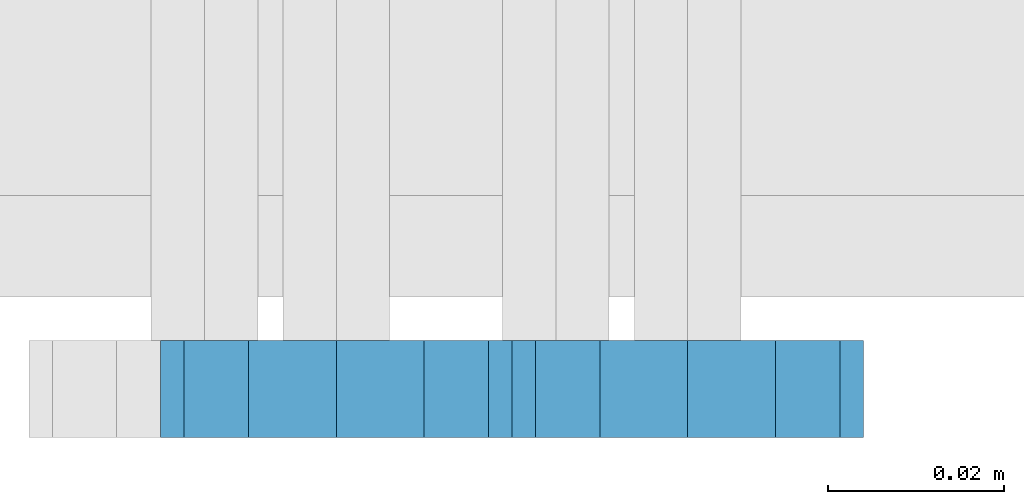
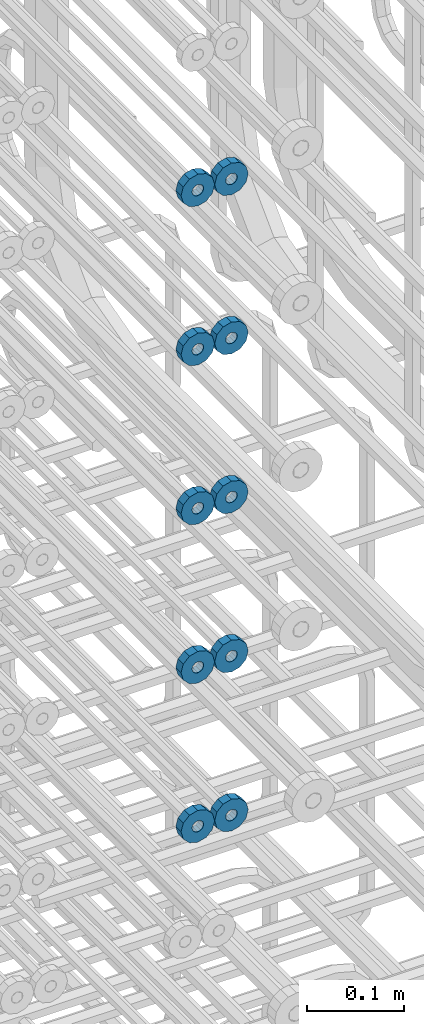
# One storey, part 167 of 177: 10 beams.
"""IFC2X3 building model written with IfcOpenShell, lengths in millimetres."""

import ifcopenshell
import ifcopenshell.guid

model = None  # the IFC model being written
_history = None  # IfcOwnerHistory: only IFC2X3 demands one
_inside = {}  # id of a spatial element -> (the spatial element, [elements in it])
_under = {}  # id of a project, library or spatial element -> (it, [spatial elements below it])
_declared = {}  # id of a project -> (the project, [libraries it declares])
_typed = {}  # id of a type object -> (the type object, [elements of that type])
_made_of = {}  # id of a material, layer set ... -> (it, [elements and type objects made of it])


def new_model(schema):
    """Start an empty IFC model of exactly this schema.

    Asked for "IFC4X3", IfcOpenShell would pick the latest addendum, in which some entities
    have other attributes; the version numbers below select the first issue.
    IFC2X3 requires an IfcOwnerHistory on every rooted entity: one is made here for all.
    """
    global model, _history
    if schema == "IFC4X3":
        model = ifcopenshell.file(schema_version=(4, 3, 0, 0))
    else:
        model = ifcopenshell.file(schema=schema)
    _inside.clear()
    _under.clear()
    _declared.clear()
    _typed.clear()
    _made_of.clear()
    _history = None
    if model.schema == "IFC2X3":
        org = make("IfcOrganization", Name="unknown")
        user = make(
            "IfcPersonAndOrganization",
            ThePerson=make("IfcPerson", FamilyName="unknown"),
            TheOrganization=org,
        )
        app = make(
            "IfcApplication",
            ApplicationDeveloper=org,
            Version="unknown",
            ApplicationFullName="unknown",
            ApplicationIdentifier="unknown",
        )
        _history = make(
            "IfcOwnerHistory",
            OwningUser=user,
            OwningApplication=app,
            ChangeAction="ADDED",
            CreationDate=0,
        )
    return model


def make(cls, **values):
    """One entity of the class cls with the attributes given. An attribute that is None is left unset."""
    return model.create_entity(
        cls, **{name: value for name, value in values.items() if value is not None}
    )


def rooted(cls, **values):
    """An entity with a GlobalId (a new one), such as an element, a storey or a relation."""
    return make(cls, GlobalId=ifcopenshell.guid.new(), OwnerHistory=_history, **values)


def si_unit(unit_type, name, prefix=None):
    """IfcSIUnit, for example si_unit("LENGTHUNIT", "METRE", prefix="MILLI")."""
    return make("IfcSIUnit", UnitType=unit_type, Prefix=prefix, Name=name)


def assignment(units):
    """IfcUnitAssignment: the units of a project."""
    return None if units is None else make("IfcUnitAssignment", Units=units)


def point(xyz):
    """IfcCartesianPoint."""
    return None if xyz is None else make("IfcCartesianPoint", Coordinates=xyz)


def direction(xyz):
    """IfcDirection."""
    return None if xyz is None else make("IfcDirection", DirectionRatios=xyz)


def frame(location, z_axis=None, x_axis=None):
    """IfcAxis2Placement3D, a coordinate frame: its origin and axes. An axis left out is left unset."""
    return make(
        "IfcAxis2Placement3D",
        Location=point(location),
        Axis=direction(z_axis),
        RefDirection=direction(x_axis),
    )


def origin_with_axes():
    """The frame at (0, 0, 0) with the z axis (0, 0, 1) and the x axis (1, 0, 0) written out."""
    return frame((0.0, 0.0, 0.0), z_axis=(0.0, 0.0, 1.0), x_axis=(1.0, 0.0, 0.0))


def place(relative_to, where):
    """IfcLocalPlacement: puts the frame where relative to a parent placement (None: the world)."""
    return make(
        "IfcLocalPlacement", PlacementRelTo=relative_to, RelativePlacement=where
    )


def context(
    kind, dimensions, precision=None, world=None, true_north=None, identifier=None
):
    """IfcGeometricRepresentationContext, for example the 3D "Model" context."""
    return make(
        "IfcGeometricRepresentationContext",
        ContextIdentifier=identifier,
        ContextType=kind,
        CoordinateSpaceDimension=dimensions,
        Precision=precision,
        WorldCoordinateSystem=world,
        TrueNorth=true_north,
    )


def subcontext(parent, identifier, kind, view, scale=None):
    """IfcGeometricRepresentationSubContext, for example "Body" below "Model"."""
    return make(
        "IfcGeometricRepresentationSubContext",
        ContextIdentifier=identifier,
        ContextType=kind,
        ParentContext=parent,
        TargetScale=scale,
        TargetView=view,
    )


def project(units=None, contexts=None):
    """IfcProject with its units and contexts."""
    return rooted(
        "IfcProject",
        Name="project",
        RepresentationContexts=contexts,
        UnitsInContext=assignment(units),
    )


def spatial(cls, under=None, at=None, **own):
    """A site, building, storey or space (cls), placed at a placement, below another one or the project."""
    s = rooted(cls, ObjectPlacement=at, **own)
    if under is not None:
        _under.setdefault(under.id(), (under, []))[1].append(s)
    return s


def faces_of(points, faces, orient=None, outer=None):
    """IfcFace entities. A face is a list of loops; a loop is a list of indices into points, from 0.

    orient and outer hold one flag for each loop. By default every Orientation is true, the
    first loop of a face is its IfcFaceOuterBound and the others are IfcFaceBound.
    """
    made = []
    for i, loops in enumerate(faces):
        bounds = []
        for j, loop in enumerate(loops):
            is_outer = j == 0 if outer is None else outer[i][j]
            bounds.append(
                make(
                    "IfcFaceOuterBound" if is_outer else "IfcFaceBound",
                    Bound=make("IfcPolyLoop", Polygon=[points[k] for k in loop]),
                    Orientation=True if orient is None else orient[i][j],
                )
            )
        made.append(make("IfcFace", Bounds=bounds))
    return made


def faceted_brep(points, faces, orient=None, outer=None, voids=None):
    """IfcFacetedBrep: a solid bounded by flat faces; with voids (closed shells), ...WithVoids."""
    shared = [point(p) for p in points]
    hull = make("IfcClosedShell", CfsFaces=faces_of(shared, faces, orient, outer))
    if voids is None:
        return make("IfcFacetedBrep", Outer=hull)
    return make(
        "IfcFacetedBrepWithVoids",
        Outer=hull,
        Voids=[
            make(cls, CfsFaces=faces_of(shared, fs, o, b)) for cls, fs, o, b in voids
        ],
    )


def shape(context_of_items, identifier, shape_type, items):
    """IfcShapeRepresentation: the items that make up one representation, for example the "Body"."""
    return make(
        "IfcShapeRepresentation",
        ContextOfItems=context_of_items,
        RepresentationIdentifier=identifier,
        RepresentationType=shape_type,
        Items=items,
    )


def material(Name=None, Category=None):
    """IfcMaterial."""
    return make("IfcMaterial", Name=Name, Category=Category)


def made_of(thing, what):
    """Note that an element or type object is made of a material, layer set ...; save() writes the relation."""
    if what is not None:
        _made_of.setdefault(what.id(), (what, []))[1].append(thing)
    return thing


def type_object(cls, material=None, **own):
    """A type object (cls), such as IfcWallType, which elements share."""
    return made_of(rooted(cls, **own), material)


def element(
    cls,
    number,
    at=None,
    inside=None,
    cuts=None,
    type_object=None,
    material=None,
    context=None,
    identifier="Body",
    shape_type=None,
    held_by="IfcProductDefinitionShape",
    body=None,
    shapes=None,
    **own,
):
    """One element of the class cls, such as IfcWall. Its Tag is "e" and its number.

    at: its placement. inside: the storey or other place that contains it. cuts: it is an
    opening in that element (IfcRelVoidsElement). A single representation is given by context,
    identifier, shape_type and body (its items); several are given by shapes. held_by: the class
    of the entity that holds the representations. save() writes the other relations.
    """
    e = rooted(cls, Tag="e%d" % number, ObjectPlacement=at, **own)
    if body is not None:
        shapes = [shape(context, identifier, shape_type, body)]
    if shapes is not None:
        e.Representation = make(held_by, Representations=shapes)
    if inside is not None:
        _inside.setdefault(inside.id(), (inside, []))[1].append(e)
    if cuts is not None:
        rooted(
            "IfcRelVoidsElement", RelatingBuildingElement=cuts, RelatedOpeningElement=e
        )
    if type_object is not None:
        _typed.setdefault(type_object.id(), (type_object, []))[1].append(e)
    return made_of(e, material)


def aggregate(whole, parts):
    """IfcRelAggregates: a whole, such as a stair, and the parts it consists of."""
    return rooted("IfcRelAggregates", RelatingObject=whole, RelatedObjects=parts)


def save(model, path):
    """Write the relations noted so far, then the file.

    IfcRelAggregates (storeys below a building ...), IfcRelContainedInSpatialStructure (elements
    in a storey), IfcRelDefinesByType, IfcRelAssociatesMaterial and IfcRelDeclares: one each for
    every whole, place, type object, material and project.
    """
    for whole, parts in _under.values():
        aggregate(whole, parts)
    for where, things in _inside.values():
        rooted(
            "IfcRelContainedInSpatialStructure",
            RelatedElements=things,
            RelatingStructure=where,
        )
    for kind, things in _typed.values():
        rooted("IfcRelDefinesByType", RelatedObjects=things, RelatingType=kind)
    for what, things in _made_of.values():
        rooted("IfcRelAssociatesMaterial", RelatedObjects=things, RelatingMaterial=what)
    for by, libraries in _declared.values():
        rooted("IfcRelDeclares", RelatingContext=by, RelatedDefinitions=libraries)
    model.write(path)


model = new_model("IFC2X3")

# Units and contexts
model_context_1 = context("Model", 3, precision=1e-05, world=origin_with_axes())
model_context_2 = context("Model", 3, precision=1e-05, world=origin_with_axes())
body_context = subcontext(model_context_2, "Body", "Model", "MODEL_VIEW")
ifc_project = project(units=[si_unit("LENGTHUNIT", "METRE", prefix="MILLI"), si_unit("AREAUNIT", "SQUARE_METRE"), si_unit("VOLUMEUNIT", "CUBIC_METRE"), si_unit("MASSUNIT", "GRAM", prefix="KILO"), si_unit("TIMEUNIT", "SECOND"), si_unit("PLANEANGLEUNIT", "RADIAN"), si_unit("SOLIDANGLEUNIT", "STERADIAN"), si_unit("THERMODYNAMICTEMPERATUREUNIT", "DEGREE_CELSIUS"), si_unit("LUMINOUSINTENSITYUNIT", "LUMEN")], contexts=[model_context_1])

# Site, building, storey
site_placement = place(None, origin_with_axes())
site = spatial("IfcSite", under=ifc_project, at=site_placement, CompositionType="ELEMENT")
building_placement = place(site_placement, origin_with_axes())
building = spatial("IfcBuilding", under=site, at=building_placement, Name="Undefined", CompositionType="ELEMENT")
storey_placement = place(building_placement, origin_with_axes())
storey = spatial("IfcBuildingStorey", under=building, at=storey_placement, Name="Undefined", CompositionType="ELEMENT", Elevation=0.0)

# Beams
ifc_material = material(Name="STEEL/Steel_Undefined")
beam_type = type_object("IfcBeamType", PredefinedType="NOTDEFINED")
beam_1_placement = place(storey_placement, frame((2036046.99847313, 6205070.98588032, 21944.9868114254), z_axis=(0.0, 0.0, -1.0), x_axis=(0.0, -1.0, 0.0)))
element("IfcBeam", 1, at=beam_1_placement, inside=storey, type_object=beam_type, material=ifc_material, context=body_context, shape_type="Brep", body=[
    faceted_brep([(-3.63797880709171e-12, -7.0, -2.3283064365387e-10), (-8.62348444298797e-13, -6.06217782649107, 3.5), (10.9999999999964, -6.06217782665044, 3.49999999976717), (10.9999999999964, -7.0, -2.3283064365387e-10), (-3.63797880709171e-12, -3.5, 6.06217782618478), (11.0, -3.5, 6.06217782618478), (-1.72469688859759e-12, 0.0, 7.0), (11.0, 0.0, 6.99999999976717), (-3.63797880709171e-12, 3.5, 6.06217782618478), (11.0, 3.5, 6.06217782618478), (-8.62348444298795e-13, 6.06217782649107, 3.5), (10.9999999999964, 6.06217782665044, 3.49999999976717), (-3.63797880709171e-12, 7.0, -2.3283064365387e-10), (10.9999999999964, 7.0, -2.3283064365387e-10), (8.62348444298797e-13, 6.06217782649107, -3.5), (10.9999999999964, 6.06217782665044, -3.50000000023283), (-3.63797880709171e-12, 3.5, -6.06217782665044), (10.9999999999964, 3.5, -6.06217782665044), (1.72469688859759e-12, -2.72004641033163e-15, -7.0), (10.9999999999964, 0.0, -7.00000000023283), (-3.63797880709171e-12, -3.5, -6.06217782665044), (10.9999999999964, -3.5, -6.06217782665044), (8.62348444298796e-13, -6.06217782649107, -3.5), (10.9999999999964, -6.06217782665044, -3.50000000023283), (0.0, -20.0000000009313, 0.0), (0.0, -17.320508075878, -10.0), (10.9999999999964, -17.320508075878, -10.0000000002328), (10.9999999999964, -20.0, -2.3283064365387e-10), (0.0, -10.0000000009313, -17.3205080756452), (11.0, -10.0, -17.320508075878), (0.0, -1.86264514923096e-09, -19.9999999998836), (10.9999999999964, 0.0, -20.0000000002328), (0.0, 9.99999999906868, -17.3205080755288), (11.0, 10.0, -17.320508075878), (0.0, 17.320508075878, -10.0), (10.9999999999964, 17.320508075878, -10.0000000002328), (0.0, 19.9999999990687, 0.0), (10.9999999999964, 20.0, -2.3283064365387e-10), (0.0, 17.3205080740154, 10.0), (11.0, 17.320508075878, 9.99999999976717), (0.0, 9.99999999906868, 17.3205080757616), (10.9999999999964, 10.0, 17.3205080754124), (0.0, 0.0, 20.0000000001164), (10.9999999999964, 0.0, 19.9999999997672), (0.0, -10.0000000009313, 17.3205080757616), (10.9999999999964, -10.0, 17.3205080754124), (0.0, -17.3205080777407, 10.0000000001164), (11.0, -17.320508075878, 9.99999999976717)], [[[0, 1, 2, 3]], [[1, 4, 5, 2]], [[4, 6, 7, 5]], [[6, 8, 9, 7]], [[8, 10, 11, 9]], [[10, 12, 13, 11]], [[12, 14, 15, 13]], [[14, 16, 17, 15]], [[16, 18, 19, 17]], [[18, 20, 21, 19]], [[20, 22, 23, 21]], [[22, 0, 3, 23]], [[24, 25, 26, 27]], [[25, 28, 29, 26]], [[28, 30, 31, 29]], [[30, 32, 33, 31]], [[32, 34, 35, 33]], [[34, 36, 37, 35]], [[36, 38, 39, 37]], [[38, 40, 41, 39]], [[40, 42, 43, 41]], [[42, 44, 45, 43]], [[44, 46, 47, 45]], [[46, 24, 27, 47]], [[29, 31, 33, 35, 37, 39, 41, 43, 45, 47, 27, 26], [5, 7, 9, 11, 13, 15, 17, 19, 21, 23, 3, 2]], [[46, 44, 42, 40, 38, 36, 34, 32, 30, 28, 25, 24], [22, 20, 18, 16, 14, 12, 10, 8, 6, 4, 1, 0]]]),
])
beam_2_placement = place(storey_placement, frame((2036006.99847313, 6205070.98588032, 21944.9868114254), z_axis=(0.0, 0.0, -1.0), x_axis=(0.0, -1.0, 0.0)))
element("IfcBeam", 2, at=beam_2_placement, inside=storey, type_object=beam_type, material=ifc_material, context=body_context, shape_type="Brep", body=[
    faceted_brep([(-3.63797880709171e-12, -7.0, -2.3283064365387e-10), (-8.62348444298797e-13, -6.06217782649107, 3.5), (10.9999999999964, -6.06217782665044, 3.49999999976717), (10.9999999999964, -7.0, -2.3283064365387e-10), (-3.63797880709171e-12, -3.5, 6.06217782618478), (11.0, -3.5, 6.06217782618478), (-1.72469688859759e-12, 0.0, 7.0), (11.0, 0.0, 6.99999999976717), (-3.63797880709171e-12, 3.5, 6.06217782618478), (11.0, 3.5, 6.06217782618478), (-8.62348444298795e-13, 6.06217782649107, 3.5), (10.9999999999964, 6.06217782665044, 3.49999999976717), (-3.63797880709171e-12, 7.0, -2.3283064365387e-10), (10.9999999999964, 7.0, -2.3283064365387e-10), (8.62348444298797e-13, 6.06217782649107, -3.5), (10.9999999999964, 6.06217782665044, -3.50000000023283), (-3.63797880709171e-12, 3.5, -6.06217782665044), (10.9999999999964, 3.5, -6.06217782665044), (1.72469688859759e-12, -2.72004641033163e-15, -7.0), (10.9999999999964, 0.0, -7.00000000023283), (-3.63797880709171e-12, -3.5, -6.06217782665044), (10.9999999999964, -3.5, -6.06217782665044), (8.62348444298796e-13, -6.06217782649107, -3.5), (10.9999999999964, -6.06217782665044, -3.50000000023283), (0.0, -20.0000000009313, 0.0), (0.0, -17.320508075878, -10.0), (10.9999999999964, -17.320508075878, -10.0000000002328), (10.9999999999964, -20.0, -2.3283064365387e-10), (0.0, -10.0000000009313, -17.3205080756452), (11.0, -10.0, -17.320508075878), (0.0, -1.86264514923096e-09, -19.9999999998836), (10.9999999999964, 0.0, -20.0000000002328), (0.0, 9.99999999906868, -17.3205080755288), (11.0, 10.0, -17.320508075878), (0.0, 17.320508075878, -10.0), (10.9999999999964, 17.320508075878, -10.0000000002328), (0.0, 19.9999999990687, 0.0), (10.9999999999964, 20.0, -2.3283064365387e-10), (0.0, 17.3205080740154, 10.0), (11.0, 17.320508075878, 9.99999999976717), (0.0, 9.99999999906868, 17.3205080757616), (10.9999999999964, 10.0, 17.3205080754124), (0.0, 0.0, 20.0000000001164), (10.9999999999964, 0.0, 19.9999999997672), (0.0, -10.0000000009313, 17.3205080757616), (10.9999999999964, -10.0, 17.3205080754124), (0.0, -17.3205080777407, 10.0000000001164), (11.0, -17.320508075878, 9.99999999976717)], [[[0, 1, 2, 3]], [[1, 4, 5, 2]], [[4, 6, 7, 5]], [[6, 8, 9, 7]], [[8, 10, 11, 9]], [[10, 12, 13, 11]], [[12, 14, 15, 13]], [[14, 16, 17, 15]], [[16, 18, 19, 17]], [[18, 20, 21, 19]], [[20, 22, 23, 21]], [[22, 0, 3, 23]], [[24, 25, 26, 27]], [[25, 28, 29, 26]], [[28, 30, 31, 29]], [[30, 32, 33, 31]], [[32, 34, 35, 33]], [[34, 36, 37, 35]], [[36, 38, 39, 37]], [[38, 40, 41, 39]], [[40, 42, 43, 41]], [[42, 44, 45, 43]], [[44, 46, 47, 45]], [[46, 24, 27, 47]], [[29, 31, 33, 35, 37, 39, 41, 43, 45, 47, 27, 26], [5, 7, 9, 11, 13, 15, 17, 19, 21, 23, 3, 2]], [[46, 44, 42, 40, 38, 36, 34, 32, 30, 28, 25, 24], [22, 20, 18, 16, 14, 12, 10, 8, 6, 4, 1, 0]]]),
])
beam_3_placement = place(storey_placement, frame((2036046.99847313, 6205070.98588032, 21744.9868114254), z_axis=(0.0, 0.0, -1.0), x_axis=(0.0, -1.0, 0.0)))
element("IfcBeam", 3, at=beam_3_placement, inside=storey, type_object=beam_type, material=ifc_material, context=body_context, shape_type="Brep", body=[
    faceted_brep([(-3.63797880709171e-12, -7.0, -2.3283064365387e-10), (-8.62348444298797e-13, -6.06217782649107, 3.5), (10.9999999999964, -6.06217782665044, 3.49999999976717), (10.9999999999964, -7.0, -2.3283064365387e-10), (-3.63797880709171e-12, -3.5, 6.06217782618478), (11.0, -3.5, 6.06217782618478), (-1.72469688859759e-12, 0.0, 7.0), (11.0, 0.0, 6.99999999976717), (-3.63797880709171e-12, 3.5, 6.06217782618478), (11.0, 3.5, 6.06217782618478), (-8.62348444298795e-13, 6.06217782649107, 3.5), (10.9999999999964, 6.06217782665044, 3.49999999976717), (-3.63797880709171e-12, 7.0, -2.3283064365387e-10), (10.9999999999964, 7.0, -2.3283064365387e-10), (8.62348444298797e-13, 6.06217782649107, -3.5), (10.9999999999964, 6.06217782665044, -3.50000000023283), (-3.63797880709171e-12, 3.5, -6.06217782665044), (10.9999999999964, 3.5, -6.06217782665044), (1.72469688859759e-12, -2.72004641033163e-15, -7.0), (10.9999999999964, 0.0, -7.00000000023283), (-3.63797880709171e-12, -3.5, -6.06217782665044), (10.9999999999964, -3.5, -6.06217782665044), (8.62348444298796e-13, -6.06217782649107, -3.5), (10.9999999999964, -6.06217782665044, -3.50000000023283), (0.0, -20.0000000009313, 0.0), (0.0, -17.320508075878, -10.0), (10.9999999999964, -17.320508075878, -10.0000000002328), (10.9999999999964, -20.0, -2.3283064365387e-10), (0.0, -10.0000000009313, -17.3205080756452), (11.0, -10.0, -17.320508075878), (0.0, -1.86264514923096e-09, -19.9999999998836), (10.9999999999964, 0.0, -20.0000000002328), (0.0, 9.99999999906868, -17.3205080755288), (11.0, 10.0, -17.320508075878), (0.0, 17.320508075878, -10.0), (10.9999999999964, 17.320508075878, -10.0000000002328), (0.0, 19.9999999990687, 0.0), (10.9999999999964, 20.0, -2.3283064365387e-10), (0.0, 17.3205080740154, 10.0), (11.0, 17.320508075878, 9.99999999976717), (0.0, 9.99999999906868, 17.3205080757616), (10.9999999999964, 10.0, 17.3205080754124), (0.0, 0.0, 20.0000000001164), (10.9999999999964, 0.0, 19.9999999997672), (0.0, -10.0000000009313, 17.3205080757616), (10.9999999999964, -10.0, 17.3205080754124), (0.0, -17.3205080777407, 10.0000000001164), (11.0, -17.320508075878, 9.99999999976717)], [[[0, 1, 2, 3]], [[1, 4, 5, 2]], [[4, 6, 7, 5]], [[6, 8, 9, 7]], [[8, 10, 11, 9]], [[10, 12, 13, 11]], [[12, 14, 15, 13]], [[14, 16, 17, 15]], [[16, 18, 19, 17]], [[18, 20, 21, 19]], [[20, 22, 23, 21]], [[22, 0, 3, 23]], [[24, 25, 26, 27]], [[25, 28, 29, 26]], [[28, 30, 31, 29]], [[30, 32, 33, 31]], [[32, 34, 35, 33]], [[34, 36, 37, 35]], [[36, 38, 39, 37]], [[38, 40, 41, 39]], [[40, 42, 43, 41]], [[42, 44, 45, 43]], [[44, 46, 47, 45]], [[46, 24, 27, 47]], [[29, 31, 33, 35, 37, 39, 41, 43, 45, 47, 27, 26], [5, 7, 9, 11, 13, 15, 17, 19, 21, 23, 3, 2]], [[46, 44, 42, 40, 38, 36, 34, 32, 30, 28, 25, 24], [22, 20, 18, 16, 14, 12, 10, 8, 6, 4, 1, 0]]]),
])
beam_4_placement = place(storey_placement, frame((2036006.99847313, 6205070.98588032, 21744.9868114254), z_axis=(0.0, 0.0, -1.0), x_axis=(0.0, -1.0, 0.0)))
element("IfcBeam", 4, at=beam_4_placement, inside=storey, type_object=beam_type, material=ifc_material, context=body_context, shape_type="Brep", body=[
    faceted_brep([(-3.63797880709171e-12, -7.0, -2.3283064365387e-10), (-8.62348444298797e-13, -6.06217782649107, 3.5), (10.9999999999964, -6.06217782665044, 3.49999999976717), (10.9999999999964, -7.0, -2.3283064365387e-10), (-3.63797880709171e-12, -3.5, 6.06217782618478), (11.0, -3.5, 6.06217782618478), (-1.72469688859759e-12, 0.0, 7.0), (11.0, 0.0, 6.99999999976717), (-3.63797880709171e-12, 3.5, 6.06217782618478), (11.0, 3.5, 6.06217782618478), (-8.62348444298795e-13, 6.06217782649107, 3.5), (10.9999999999964, 6.06217782665044, 3.49999999976717), (-3.63797880709171e-12, 7.0, -2.3283064365387e-10), (10.9999999999964, 7.0, -2.3283064365387e-10), (8.62348444298797e-13, 6.06217782649107, -3.5), (10.9999999999964, 6.06217782665044, -3.50000000023283), (-3.63797880709171e-12, 3.5, -6.06217782665044), (10.9999999999964, 3.5, -6.06217782665044), (1.72469688859759e-12, -2.72004641033163e-15, -7.0), (10.9999999999964, 0.0, -7.00000000023283), (-3.63797880709171e-12, -3.5, -6.06217782665044), (10.9999999999964, -3.5, -6.06217782665044), (8.62348444298796e-13, -6.06217782649107, -3.5), (10.9999999999964, -6.06217782665044, -3.50000000023283), (0.0, -20.0000000009313, 0.0), (0.0, -17.320508075878, -10.0), (10.9999999999964, -17.320508075878, -10.0000000002328), (10.9999999999964, -20.0, -2.3283064365387e-10), (0.0, -10.0000000009313, -17.3205080756452), (11.0, -10.0, -17.320508075878), (0.0, -1.86264514923096e-09, -19.9999999998836), (10.9999999999964, 0.0, -20.0000000002328), (0.0, 9.99999999906868, -17.3205080755288), (11.0, 10.0, -17.320508075878), (0.0, 17.320508075878, -10.0), (10.9999999999964, 17.320508075878, -10.0000000002328), (0.0, 19.9999999990687, 0.0), (10.9999999999964, 20.0, -2.3283064365387e-10), (0.0, 17.3205080740154, 10.0), (11.0, 17.320508075878, 9.99999999976717), (0.0, 9.99999999906868, 17.3205080757616), (10.9999999999964, 10.0, 17.3205080754124), (0.0, 0.0, 20.0000000001164), (10.9999999999964, 0.0, 19.9999999997672), (0.0, -10.0000000009313, 17.3205080757616), (10.9999999999964, -10.0, 17.3205080754124), (0.0, -17.3205080777407, 10.0000000001164), (11.0, -17.320508075878, 9.99999999976717)], [[[0, 1, 2, 3]], [[1, 4, 5, 2]], [[4, 6, 7, 5]], [[6, 8, 9, 7]], [[8, 10, 11, 9]], [[10, 12, 13, 11]], [[12, 14, 15, 13]], [[14, 16, 17, 15]], [[16, 18, 19, 17]], [[18, 20, 21, 19]], [[20, 22, 23, 21]], [[22, 0, 3, 23]], [[24, 25, 26, 27]], [[25, 28, 29, 26]], [[28, 30, 31, 29]], [[30, 32, 33, 31]], [[32, 34, 35, 33]], [[34, 36, 37, 35]], [[36, 38, 39, 37]], [[38, 40, 41, 39]], [[40, 42, 43, 41]], [[42, 44, 45, 43]], [[44, 46, 47, 45]], [[46, 24, 27, 47]], [[29, 31, 33, 35, 37, 39, 41, 43, 45, 47, 27, 26], [5, 7, 9, 11, 13, 15, 17, 19, 21, 23, 3, 2]], [[46, 44, 42, 40, 38, 36, 34, 32, 30, 28, 25, 24], [22, 20, 18, 16, 14, 12, 10, 8, 6, 4, 1, 0]]]),
])
beam_5_placement = place(storey_placement, frame((2036046.99847313, 6205070.98588032, 21544.9868114254), z_axis=(0.0, 0.0, -1.0), x_axis=(0.0, -1.0, 0.0)))
element("IfcBeam", 5, at=beam_5_placement, inside=storey, type_object=beam_type, material=ifc_material, context=body_context, shape_type="Brep", body=[
    faceted_brep([(-3.63797880709171e-12, -7.0, -2.3283064365387e-10), (-8.62348444298797e-13, -6.06217782649107, 3.5), (10.9999999999964, -6.06217782665044, 3.49999999976717), (10.9999999999964, -7.0, -2.3283064365387e-10), (-3.63797880709171e-12, -3.5, 6.06217782618478), (11.0, -3.5, 6.06217782618478), (-1.72469688859759e-12, 0.0, 7.0), (11.0, 0.0, 6.99999999976717), (-3.63797880709171e-12, 3.5, 6.06217782618478), (11.0, 3.5, 6.06217782618478), (-8.62348444298795e-13, 6.06217782649107, 3.5), (10.9999999999964, 6.06217782665044, 3.49999999976717), (-3.63797880709171e-12, 7.0, -2.3283064365387e-10), (10.9999999999964, 7.0, -2.3283064365387e-10), (8.62348444298797e-13, 6.06217782649107, -3.5), (10.9999999999964, 6.06217782665044, -3.50000000023283), (-3.63797880709171e-12, 3.5, -6.06217782665044), (10.9999999999964, 3.5, -6.06217782665044), (1.72469688859759e-12, -2.72004641033163e-15, -7.0), (10.9999999999964, 0.0, -7.00000000023283), (-3.63797880709171e-12, -3.5, -6.06217782665044), (10.9999999999964, -3.5, -6.06217782665044), (8.62348444298796e-13, -6.06217782649107, -3.5), (10.9999999999964, -6.06217782665044, -3.50000000023283), (0.0, -20.0000000009313, 0.0), (0.0, -17.320508075878, -10.0), (10.9999999999964, -17.320508075878, -10.0000000002328), (10.9999999999964, -20.0, -2.3283064365387e-10), (0.0, -10.0000000009313, -17.3205080756452), (11.0, -10.0, -17.320508075878), (0.0, -1.86264514923096e-09, -19.9999999998836), (10.9999999999964, 0.0, -20.0000000002328), (0.0, 9.99999999906868, -17.3205080755288), (11.0, 10.0, -17.320508075878), (0.0, 17.320508075878, -10.0), (10.9999999999964, 17.320508075878, -10.0000000002328), (0.0, 19.9999999990687, 0.0), (10.9999999999964, 20.0, -2.3283064365387e-10), (0.0, 17.3205080740154, 10.0), (11.0, 17.320508075878, 9.99999999976717), (0.0, 9.99999999906868, 17.3205080757616), (10.9999999999964, 10.0, 17.3205080754124), (0.0, 0.0, 20.0000000001164), (10.9999999999964, 0.0, 19.9999999997672), (0.0, -10.0000000009313, 17.3205080757616), (10.9999999999964, -10.0, 17.3205080754124), (0.0, -17.3205080777407, 10.0000000001164), (11.0, -17.320508075878, 9.99999999976717)], [[[0, 1, 2, 3]], [[1, 4, 5, 2]], [[4, 6, 7, 5]], [[6, 8, 9, 7]], [[8, 10, 11, 9]], [[10, 12, 13, 11]], [[12, 14, 15, 13]], [[14, 16, 17, 15]], [[16, 18, 19, 17]], [[18, 20, 21, 19]], [[20, 22, 23, 21]], [[22, 0, 3, 23]], [[24, 25, 26, 27]], [[25, 28, 29, 26]], [[28, 30, 31, 29]], [[30, 32, 33, 31]], [[32, 34, 35, 33]], [[34, 36, 37, 35]], [[36, 38, 39, 37]], [[38, 40, 41, 39]], [[40, 42, 43, 41]], [[42, 44, 45, 43]], [[44, 46, 47, 45]], [[46, 24, 27, 47]], [[29, 31, 33, 35, 37, 39, 41, 43, 45, 47, 27, 26], [5, 7, 9, 11, 13, 15, 17, 19, 21, 23, 3, 2]], [[46, 44, 42, 40, 38, 36, 34, 32, 30, 28, 25, 24], [22, 20, 18, 16, 14, 12, 10, 8, 6, 4, 1, 0]]]),
])
beam_6_placement = place(storey_placement, frame((2036006.99847313, 6205070.98588032, 21544.9868114254), z_axis=(0.0, 0.0, -1.0), x_axis=(0.0, -1.0, 0.0)))
element("IfcBeam", 6, at=beam_6_placement, inside=storey, type_object=beam_type, material=ifc_material, context=body_context, shape_type="Brep", body=[
    faceted_brep([(-3.63797880709171e-12, -7.0, -2.3283064365387e-10), (-8.62348444298797e-13, -6.06217782649107, 3.5), (10.9999999999964, -6.06217782665044, 3.49999999976717), (10.9999999999964, -7.0, -2.3283064365387e-10), (-3.63797880709171e-12, -3.5, 6.06217782618478), (11.0, -3.5, 6.06217782618478), (-1.72469688859759e-12, 0.0, 7.0), (11.0, 0.0, 6.99999999976717), (-3.63797880709171e-12, 3.5, 6.06217782618478), (11.0, 3.5, 6.06217782618478), (-8.62348444298795e-13, 6.06217782649107, 3.5), (10.9999999999964, 6.06217782665044, 3.49999999976717), (-3.63797880709171e-12, 7.0, -2.3283064365387e-10), (10.9999999999964, 7.0, -2.3283064365387e-10), (8.62348444298797e-13, 6.06217782649107, -3.5), (10.9999999999964, 6.06217782665044, -3.50000000023283), (-3.63797880709171e-12, 3.5, -6.06217782665044), (10.9999999999964, 3.5, -6.06217782665044), (1.72469688859759e-12, -2.72004641033163e-15, -7.0), (10.9999999999964, 0.0, -7.00000000023283), (-3.63797880709171e-12, -3.5, -6.06217782665044), (10.9999999999964, -3.5, -6.06217782665044), (8.62348444298796e-13, -6.06217782649107, -3.5), (10.9999999999964, -6.06217782665044, -3.50000000023283), (0.0, -20.0000000009313, 0.0), (0.0, -17.320508075878, -10.0), (10.9999999999964, -17.320508075878, -10.0000000002328), (10.9999999999964, -20.0, -2.3283064365387e-10), (0.0, -10.0000000009313, -17.3205080756452), (11.0, -10.0, -17.320508075878), (0.0, -1.86264514923096e-09, -19.9999999998836), (10.9999999999964, 0.0, -20.0000000002328), (0.0, 9.99999999906868, -17.3205080755288), (11.0, 10.0, -17.320508075878), (0.0, 17.320508075878, -10.0), (10.9999999999964, 17.320508075878, -10.0000000002328), (0.0, 19.9999999990687, 0.0), (10.9999999999964, 20.0, -2.3283064365387e-10), (0.0, 17.3205080740154, 10.0), (11.0, 17.320508075878, 9.99999999976717), (0.0, 9.99999999906868, 17.3205080757616), (10.9999999999964, 10.0, 17.3205080754124), (0.0, 0.0, 20.0000000001164), (10.9999999999964, 0.0, 19.9999999997672), (0.0, -10.0000000009313, 17.3205080757616), (10.9999999999964, -10.0, 17.3205080754124), (0.0, -17.3205080777407, 10.0000000001164), (11.0, -17.320508075878, 9.99999999976717)], [[[0, 1, 2, 3]], [[1, 4, 5, 2]], [[4, 6, 7, 5]], [[6, 8, 9, 7]], [[8, 10, 11, 9]], [[10, 12, 13, 11]], [[12, 14, 15, 13]], [[14, 16, 17, 15]], [[16, 18, 19, 17]], [[18, 20, 21, 19]], [[20, 22, 23, 21]], [[22, 0, 3, 23]], [[24, 25, 26, 27]], [[25, 28, 29, 26]], [[28, 30, 31, 29]], [[30, 32, 33, 31]], [[32, 34, 35, 33]], [[34, 36, 37, 35]], [[36, 38, 39, 37]], [[38, 40, 41, 39]], [[40, 42, 43, 41]], [[42, 44, 45, 43]], [[44, 46, 47, 45]], [[46, 24, 27, 47]], [[29, 31, 33, 35, 37, 39, 41, 43, 45, 47, 27, 26], [5, 7, 9, 11, 13, 15, 17, 19, 21, 23, 3, 2]], [[46, 44, 42, 40, 38, 36, 34, 32, 30, 28, 25, 24], [22, 20, 18, 16, 14, 12, 10, 8, 6, 4, 1, 0]]]),
])
beam_7_placement = place(storey_placement, frame((2036046.99847313, 6205070.98588033, 21344.9868114254), z_axis=(0.0, 0.0, -1.0), x_axis=(0.0, -1.0, 0.0)))
element("IfcBeam", 7, at=beam_7_placement, inside=storey, type_object=beam_type, material=ifc_material, context=body_context, shape_type="Brep", body=[
    faceted_brep([(-3.63797880709171e-12, -7.0, -2.3283064365387e-10), (-8.62348444298797e-13, -6.06217782649107, 3.5), (10.9999999999964, -6.06217782665044, 3.49999999976717), (10.9999999999964, -7.0, -2.3283064365387e-10), (-3.63797880709171e-12, -3.5, 6.06217782618478), (11.0, -3.5, 6.06217782618478), (-1.72469688859759e-12, 0.0, 7.0), (11.0, 0.0, 6.99999999976717), (-3.63797880709171e-12, 3.5, 6.06217782618478), (11.0, 3.5, 6.06217782618478), (-8.62348444298795e-13, 6.06217782649107, 3.5), (10.9999999999964, 6.06217782665044, 3.49999999976717), (-3.63797880709171e-12, 7.0, -2.3283064365387e-10), (10.9999999999964, 7.0, -2.3283064365387e-10), (8.62348444298797e-13, 6.06217782649107, -3.5), (10.9999999999964, 6.06217782665044, -3.50000000023283), (-3.63797880709171e-12, 3.5, -6.06217782665044), (10.9999999999964, 3.5, -6.06217782665044), (1.72469688859759e-12, -2.72004641033163e-15, -7.0), (10.9999999999964, 0.0, -7.00000000023283), (-3.63797880709171e-12, -3.5, -6.06217782665044), (10.9999999999964, -3.5, -6.06217782665044), (8.62348444298796e-13, -6.06217782649107, -3.5), (10.9999999999964, -6.06217782665044, -3.50000000023283), (0.0, -20.0000000009313, 0.0), (0.0, -17.320508075878, -10.0), (10.9999999999964, -17.320508075878, -10.0000000002328), (10.9999999999964, -20.0, -2.3283064365387e-10), (0.0, -10.0000000009313, -17.3205080756452), (11.0, -10.0, -17.320508075878), (0.0, -1.86264514923096e-09, -19.9999999998836), (10.9999999999964, 0.0, -20.0000000002328), (0.0, 9.99999999906868, -17.3205080755288), (11.0, 10.0, -17.320508075878), (0.0, 17.320508075878, -10.0), (10.9999999999964, 17.320508075878, -10.0000000002328), (0.0, 19.9999999990687, 0.0), (10.9999999999964, 20.0, -2.3283064365387e-10), (0.0, 17.3205080740154, 10.0), (11.0, 17.320508075878, 9.99999999976717), (0.0, 9.99999999906868, 17.3205080757616), (10.9999999999964, 10.0, 17.3205080754124), (0.0, 0.0, 20.0000000001164), (10.9999999999964, 0.0, 19.9999999997672), (0.0, -10.0000000009313, 17.3205080757616), (10.9999999999964, -10.0, 17.3205080754124), (0.0, -17.3205080777407, 10.0000000001164), (11.0, -17.320508075878, 9.99999999976717)], [[[0, 1, 2, 3]], [[1, 4, 5, 2]], [[4, 6, 7, 5]], [[6, 8, 9, 7]], [[8, 10, 11, 9]], [[10, 12, 13, 11]], [[12, 14, 15, 13]], [[14, 16, 17, 15]], [[16, 18, 19, 17]], [[18, 20, 21, 19]], [[20, 22, 23, 21]], [[22, 0, 3, 23]], [[24, 25, 26, 27]], [[25, 28, 29, 26]], [[28, 30, 31, 29]], [[30, 32, 33, 31]], [[32, 34, 35, 33]], [[34, 36, 37, 35]], [[36, 38, 39, 37]], [[38, 40, 41, 39]], [[40, 42, 43, 41]], [[42, 44, 45, 43]], [[44, 46, 47, 45]], [[46, 24, 27, 47]], [[29, 31, 33, 35, 37, 39, 41, 43, 45, 47, 27, 26], [5, 7, 9, 11, 13, 15, 17, 19, 21, 23, 3, 2]], [[46, 44, 42, 40, 38, 36, 34, 32, 30, 28, 25, 24], [22, 20, 18, 16, 14, 12, 10, 8, 6, 4, 1, 0]]]),
])
beam_8_placement = place(storey_placement, frame((2036006.99847313, 6205070.98588033, 21344.9868114254), z_axis=(0.0, 0.0, -1.0), x_axis=(0.0, -1.0, 0.0)))
element("IfcBeam", 8, at=beam_8_placement, inside=storey, type_object=beam_type, material=ifc_material, context=body_context, shape_type="Brep", body=[
    faceted_brep([(-3.63797880709171e-12, -7.0, -2.3283064365387e-10), (-8.62348444298797e-13, -6.06217782649107, 3.5), (10.9999999999964, -6.06217782665044, 3.49999999976717), (10.9999999999964, -7.0, -2.3283064365387e-10), (-3.63797880709171e-12, -3.5, 6.06217782618478), (11.0, -3.5, 6.06217782618478), (-1.72469688859759e-12, 0.0, 7.0), (11.0, 0.0, 6.99999999976717), (-3.63797880709171e-12, 3.5, 6.06217782618478), (11.0, 3.5, 6.06217782618478), (-8.62348444298795e-13, 6.06217782649107, 3.5), (10.9999999999964, 6.06217782665044, 3.49999999976717), (-3.63797880709171e-12, 7.0, -2.3283064365387e-10), (10.9999999999964, 7.0, -2.3283064365387e-10), (8.62348444298797e-13, 6.06217782649107, -3.5), (10.9999999999964, 6.06217782665044, -3.50000000023283), (-3.63797880709171e-12, 3.5, -6.06217782665044), (10.9999999999964, 3.5, -6.06217782665044), (1.72469688859759e-12, -2.72004641033163e-15, -7.0), (10.9999999999964, 0.0, -7.00000000023283), (-3.63797880709171e-12, -3.5, -6.06217782665044), (10.9999999999964, -3.5, -6.06217782665044), (8.62348444298796e-13, -6.06217782649107, -3.5), (10.9999999999964, -6.06217782665044, -3.50000000023283), (0.0, -20.0000000009313, 0.0), (0.0, -17.320508075878, -10.0), (10.9999999999964, -17.320508075878, -10.0000000002328), (10.9999999999964, -20.0, -2.3283064365387e-10), (0.0, -10.0000000009313, -17.3205080756452), (11.0, -10.0, -17.320508075878), (0.0, -1.86264514923096e-09, -19.9999999998836), (10.9999999999964, 0.0, -20.0000000002328), (0.0, 9.99999999906868, -17.3205080755288), (11.0, 10.0, -17.320508075878), (0.0, 17.320508075878, -10.0), (10.9999999999964, 17.320508075878, -10.0000000002328), (0.0, 19.9999999990687, 0.0), (10.9999999999964, 20.0, -2.3283064365387e-10), (0.0, 17.3205080740154, 10.0), (11.0, 17.320508075878, 9.99999999976717), (0.0, 9.99999999906868, 17.3205080757616), (10.9999999999964, 10.0, 17.3205080754124), (0.0, 0.0, 20.0000000001164), (10.9999999999964, 0.0, 19.9999999997672), (0.0, -10.0000000009313, 17.3205080757616), (10.9999999999964, -10.0, 17.3205080754124), (0.0, -17.3205080777407, 10.0000000001164), (11.0, -17.320508075878, 9.99999999976717)], [[[0, 1, 2, 3]], [[1, 4, 5, 2]], [[4, 6, 7, 5]], [[6, 8, 9, 7]], [[8, 10, 11, 9]], [[10, 12, 13, 11]], [[12, 14, 15, 13]], [[14, 16, 17, 15]], [[16, 18, 19, 17]], [[18, 20, 21, 19]], [[20, 22, 23, 21]], [[22, 0, 3, 23]], [[24, 25, 26, 27]], [[25, 28, 29, 26]], [[28, 30, 31, 29]], [[30, 32, 33, 31]], [[32, 34, 35, 33]], [[34, 36, 37, 35]], [[36, 38, 39, 37]], [[38, 40, 41, 39]], [[40, 42, 43, 41]], [[42, 44, 45, 43]], [[44, 46, 47, 45]], [[46, 24, 27, 47]], [[29, 31, 33, 35, 37, 39, 41, 43, 45, 47, 27, 26], [5, 7, 9, 11, 13, 15, 17, 19, 21, 23, 3, 2]], [[46, 44, 42, 40, 38, 36, 34, 32, 30, 28, 25, 24], [22, 20, 18, 16, 14, 12, 10, 8, 6, 4, 1, 0]]]),
])
beam_9_placement = place(storey_placement, frame((2036046.99847313, 6205070.98588033, 21144.9868114254), z_axis=(0.0, 0.0, -1.0), x_axis=(0.0, -1.0, 0.0)))
element("IfcBeam", 9, at=beam_9_placement, inside=storey, type_object=beam_type, material=ifc_material, context=body_context, shape_type="Brep", body=[
    faceted_brep([(-3.63797880709171e-12, -7.0, -2.3283064365387e-10), (-8.62348444298797e-13, -6.06217782649107, 3.5), (10.9999999999964, -6.06217782665044, 3.49999999976717), (10.9999999999964, -7.0, -2.3283064365387e-10), (-3.63797880709171e-12, -3.5, 6.06217782618478), (11.0, -3.5, 6.06217782618478), (-1.72469688859759e-12, 0.0, 7.0), (11.0, 0.0, 6.99999999976717), (-3.63797880709171e-12, 3.5, 6.06217782618478), (11.0, 3.5, 6.06217782618478), (-8.62348444298795e-13, 6.06217782649107, 3.5), (10.9999999999964, 6.06217782665044, 3.49999999976717), (-3.63797880709171e-12, 7.0, -2.3283064365387e-10), (10.9999999999964, 7.0, -2.3283064365387e-10), (8.62348444298797e-13, 6.06217782649107, -3.5), (10.9999999999964, 6.06217782665044, -3.50000000023283), (-3.63797880709171e-12, 3.5, -6.06217782665044), (10.9999999999964, 3.5, -6.06217782665044), (1.72469688859759e-12, -2.72004641033163e-15, -7.0), (10.9999999999964, 0.0, -7.00000000023283), (-3.63797880709171e-12, -3.5, -6.06217782665044), (10.9999999999964, -3.5, -6.06217782665044), (8.62348444298796e-13, -6.06217782649107, -3.5), (10.9999999999964, -6.06217782665044, -3.50000000023283), (0.0, -20.0000000009313, 0.0), (0.0, -17.320508075878, -10.0), (10.9999999999964, -17.320508075878, -10.0000000002328), (10.9999999999964, -20.0, -2.3283064365387e-10), (0.0, -10.0000000009313, -17.3205080756452), (11.0, -10.0, -17.320508075878), (0.0, -1.86264514923096e-09, -19.9999999998836), (10.9999999999964, 0.0, -20.0000000002328), (0.0, 9.99999999906868, -17.3205080755288), (11.0, 10.0, -17.320508075878), (0.0, 17.320508075878, -10.0), (10.9999999999964, 17.320508075878, -10.0000000002328), (0.0, 19.9999999990687, 0.0), (10.9999999999964, 20.0, -2.3283064365387e-10), (0.0, 17.3205080740154, 10.0), (11.0, 17.320508075878, 9.99999999976717), (0.0, 9.99999999906868, 17.3205080757616), (10.9999999999964, 10.0, 17.3205080754124), (0.0, 0.0, 20.0000000001164), (10.9999999999964, 0.0, 19.9999999997672), (0.0, -10.0000000009313, 17.3205080757616), (10.9999999999964, -10.0, 17.3205080754124), (0.0, -17.3205080777407, 10.0000000001164), (11.0, -17.320508075878, 9.99999999976717)], [[[0, 1, 2, 3]], [[1, 4, 5, 2]], [[4, 6, 7, 5]], [[6, 8, 9, 7]], [[8, 10, 11, 9]], [[10, 12, 13, 11]], [[12, 14, 15, 13]], [[14, 16, 17, 15]], [[16, 18, 19, 17]], [[18, 20, 21, 19]], [[20, 22, 23, 21]], [[22, 0, 3, 23]], [[24, 25, 26, 27]], [[25, 28, 29, 26]], [[28, 30, 31, 29]], [[30, 32, 33, 31]], [[32, 34, 35, 33]], [[34, 36, 37, 35]], [[36, 38, 39, 37]], [[38, 40, 41, 39]], [[40, 42, 43, 41]], [[42, 44, 45, 43]], [[44, 46, 47, 45]], [[46, 24, 27, 47]], [[29, 31, 33, 35, 37, 39, 41, 43, 45, 47, 27, 26], [5, 7, 9, 11, 13, 15, 17, 19, 21, 23, 3, 2]], [[46, 44, 42, 40, 38, 36, 34, 32, 30, 28, 25, 24], [22, 20, 18, 16, 14, 12, 10, 8, 6, 4, 1, 0]]]),
])
beam_10_placement = place(storey_placement, frame((2036006.99847313, 6205070.98588033, 21144.9868114254), z_axis=(0.0, 0.0, -1.0), x_axis=(0.0, -1.0, 0.0)))
element("IfcBeam", 10, at=beam_10_placement, inside=storey, type_object=beam_type, material=ifc_material, context=body_context, shape_type="Brep", body=[
    faceted_brep([(-3.63797880709171e-12, -7.0, -2.3283064365387e-10), (-8.62348444298797e-13, -6.06217782649107, 3.5), (10.9999999999964, -6.06217782665044, 3.49999999976717), (10.9999999999964, -7.0, -2.3283064365387e-10), (-3.63797880709171e-12, -3.5, 6.06217782618478), (11.0, -3.5, 6.06217782618478), (-1.72469688859759e-12, 0.0, 7.0), (11.0, 0.0, 6.99999999976717), (-3.63797880709171e-12, 3.5, 6.06217782618478), (11.0, 3.5, 6.06217782618478), (-8.62348444298795e-13, 6.06217782649107, 3.5), (10.9999999999964, 6.06217782665044, 3.49999999976717), (-3.63797880709171e-12, 7.0, -2.3283064365387e-10), (10.9999999999964, 7.0, -2.3283064365387e-10), (8.62348444298797e-13, 6.06217782649107, -3.5), (10.9999999999964, 6.06217782665044, -3.50000000023283), (-3.63797880709171e-12, 3.5, -6.06217782665044), (10.9999999999964, 3.5, -6.06217782665044), (1.72469688859759e-12, -2.72004641033163e-15, -7.0), (10.9999999999964, 0.0, -7.00000000023283), (-3.63797880709171e-12, -3.5, -6.06217782665044), (10.9999999999964, -3.5, -6.06217782665044), (8.62348444298796e-13, -6.06217782649107, -3.5), (10.9999999999964, -6.06217782665044, -3.50000000023283), (0.0, -20.0000000009313, 0.0), (0.0, -17.320508075878, -10.0), (10.9999999999964, -17.320508075878, -10.0000000002328), (10.9999999999964, -20.0, -2.3283064365387e-10), (0.0, -10.0000000009313, -17.3205080756452), (11.0, -10.0, -17.320508075878), (0.0, -1.86264514923096e-09, -19.9999999998836), (10.9999999999964, 0.0, -20.0000000002328), (0.0, 9.99999999906868, -17.3205080755288), (11.0, 10.0, -17.320508075878), (0.0, 17.320508075878, -10.0), (10.9999999999964, 17.320508075878, -10.0000000002328), (0.0, 19.9999999990687, 0.0), (10.9999999999964, 20.0, -2.3283064365387e-10), (0.0, 17.3205080740154, 10.0), (11.0, 17.320508075878, 9.99999999976717), (0.0, 9.99999999906868, 17.3205080757616), (10.9999999999964, 10.0, 17.3205080754124), (0.0, 0.0, 20.0000000001164), (10.9999999999964, 0.0, 19.9999999997672), (0.0, -10.0000000009313, 17.3205080757616), (10.9999999999964, -10.0, 17.3205080754124), (0.0, -17.3205080777407, 10.0000000001164), (11.0, -17.320508075878, 9.99999999976717)], [[[0, 1, 2, 3]], [[1, 4, 5, 2]], [[4, 6, 7, 5]], [[6, 8, 9, 7]], [[8, 10, 11, 9]], [[10, 12, 13, 11]], [[12, 14, 15, 13]], [[14, 16, 17, 15]], [[16, 18, 19, 17]], [[18, 20, 21, 19]], [[20, 22, 23, 21]], [[22, 0, 3, 23]], [[24, 25, 26, 27]], [[25, 28, 29, 26]], [[28, 30, 31, 29]], [[30, 32, 33, 31]], [[32, 34, 35, 33]], [[34, 36, 37, 35]], [[36, 38, 39, 37]], [[38, 40, 41, 39]], [[40, 42, 43, 41]], [[42, 44, 45, 43]], [[44, 46, 47, 45]], [[46, 24, 27, 47]], [[29, 31, 33, 35, 37, 39, 41, 43, 45, 47, 27, 26], [5, 7, 9, 11, 13, 15, 17, 19, 21, 23, 3, 2]], [[46, 44, 42, 40, 38, 36, 34, 32, 30, 28, 25, 24], [22, 20, 18, 16, 14, 12, 10, 8, 6, 4, 1, 0]]]),
])

save(model, "model.ifc")
